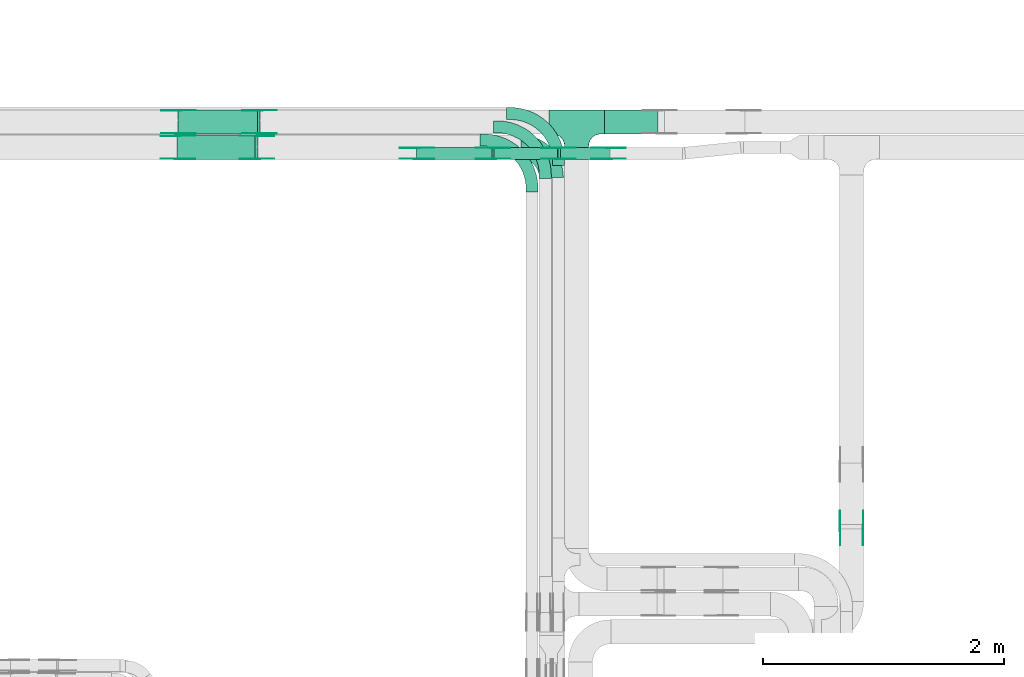
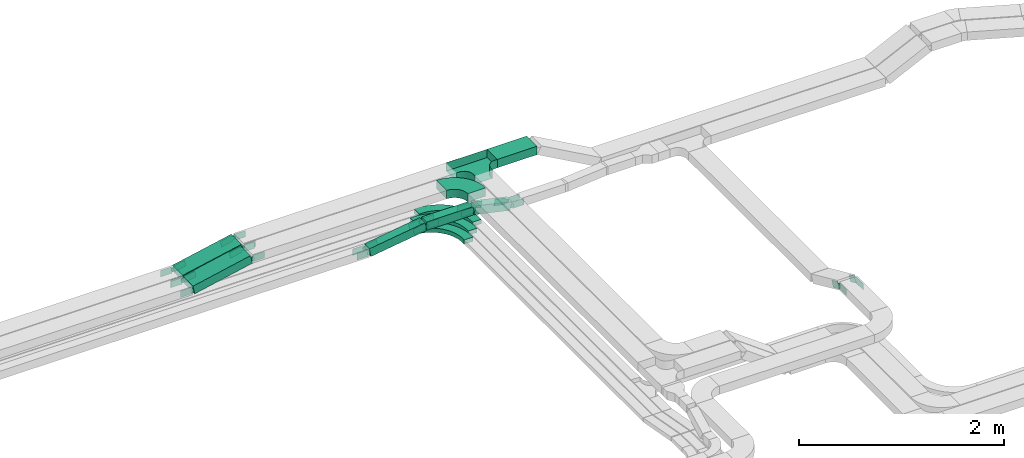
# One storey, part 12 of 23: 41 flow fittings, 6 flow segments.
"""IFC2X3 building model written with IfcOpenShell, lengths in millimetres."""

from ifc_helpers import new_model, entity, si_unit, converted_unit, derived_unit, direction, frame, frame_2d, origin, origin_2d_with_axis, place, context, subcontext, project, spatial, polyline, circle_curve, parameter, trimmed, segment, composite_curve, rectangle, outline, extrude, faceted_brep, source, transform, mapped, material, type_object, type_shapes, element, save


model = new_model("IFC2X3")

# Units and contexts
model_context = context("Model", 3, precision=0.01, world=origin(), true_north=direction((6.12303176911189e-17, 1.0)))
body_context = subcontext(model_context, "Body", "Model", "MODEL_VIEW")
ifc_project = project(units=[si_unit("LENGTHUNIT", "METRE", prefix="MILLI"), si_unit("AREAUNIT", "SQUARE_METRE"), si_unit("VOLUMEUNIT", "CUBIC_METRE"), converted_unit("PLANEANGLEUNIT", "DEGREE", entity("IfcRatioMeasure", 0.0174532925199433), si_unit("PLANEANGLEUNIT", "RADIAN"), dimensions=[0, 0, 0, 0, 0, 0, 0]), si_unit("MASSUNIT", "GRAM", prefix="KILO"), derived_unit("MASSDENSITYUNIT", [(si_unit("MASSUNIT", "GRAM", prefix="KILO"), 1), (si_unit("LENGTHUNIT", "METRE"), -3)]), derived_unit("MOMENTOFINERTIAUNIT", [(si_unit("LENGTHUNIT", "METRE"), 4)]), si_unit("TIMEUNIT", "SECOND"), si_unit("FREQUENCYUNIT", "HERTZ"), si_unit("THERMODYNAMICTEMPERATUREUNIT", "DEGREE_CELSIUS"), derived_unit("THERMALTRANSMITTANCEUNIT", [(si_unit("MASSUNIT", "GRAM", prefix="KILO"), 1), (si_unit("THERMODYNAMICTEMPERATUREUNIT", "KELVIN"), -1), (si_unit("TIMEUNIT", "SECOND"), -3)]), derived_unit("VOLUMETRICFLOWRATEUNIT", [(si_unit("LENGTHUNIT", "METRE"), 3), (si_unit("TIMEUNIT", "SECOND"), -1)]), derived_unit("MASSFLOWRATEUNIT", [(si_unit("MASSUNIT", "GRAM", prefix="KILO"), 1), (si_unit("TIMEUNIT", "SECOND"), -1)]), derived_unit("ROTATIONALFREQUENCYUNIT", [(si_unit("TIMEUNIT", "SECOND"), -1)]), si_unit("ELECTRICCURRENTUNIT", "AMPERE"), si_unit("ELECTRICVOLTAGEUNIT", "VOLT"), si_unit("POWERUNIT", "WATT"), si_unit("FORCEUNIT", "NEWTON", prefix="KILO"), si_unit("ILLUMINANCEUNIT", "LUX"), si_unit("LUMINOUSFLUXUNIT", "LUMEN"), si_unit("LUMINOUSINTENSITYUNIT", "CANDELA"), derived_unit("USERDEFINED", [(si_unit("MASSUNIT", "GRAM", prefix="KILO"), -1), (si_unit("LENGTHUNIT", "METRE"), -2), (si_unit("TIMEUNIT", "SECOND"), 3), (si_unit("LUMINOUSFLUXUNIT", "LUMEN"), 1)]), derived_unit("LINEARVELOCITYUNIT", [(si_unit("LENGTHUNIT", "METRE"), 1), (si_unit("TIMEUNIT", "SECOND"), -1)]), si_unit("PRESSUREUNIT", "PASCAL"), derived_unit("USERDEFINED", [(si_unit("LENGTHUNIT", "METRE"), -2), (si_unit("MASSUNIT", "GRAM", prefix="KILO"), 1), (si_unit("TIMEUNIT", "SECOND"), -2)]), derived_unit("LINEARFORCEUNIT", [(si_unit("MASSUNIT", "GRAM", prefix="KILO"), 1), (si_unit("LENGTHUNIT", "METRE"), 1), (si_unit("TIMEUNIT", "SECOND"), -2), (si_unit("LENGTHUNIT", "METRE"), -1)]), derived_unit("PLANARFORCEUNIT", [(si_unit("MASSUNIT", "GRAM", prefix="KILO"), 1), (si_unit("LENGTHUNIT", "METRE"), 1), (si_unit("TIMEUNIT", "SECOND"), -2), (si_unit("LENGTHUNIT", "METRE"), -2)])], contexts=[model_context])

# Site, building, storey
site_placement = place(None, origin())
site = spatial("IfcSite", under=ifc_project, at=site_placement, CompositionType="ELEMENT")
building_placement = place(site_placement, origin())
building = spatial("IfcBuilding", under=site, at=building_placement, CompositionType="ELEMENT")
storey_placement = place(building_placement, frame((0.0, 0.0, 24000.0)))
storey = spatial("IfcBuildingStorey", under=building, at=storey_placement, CompositionType="ELEMENT", Elevation=24000.0)

# Flow segments
cable_carrier_segment_type = type_object("IfcCableCarrierSegmentType", PredefinedType="CABLETRAYSEGMENT")
flow_segment_1_placement = place(storey_placement, frame((33483.08, 14577.82, 3040.0)))
element("IfcFlowSegment", 1, at=flow_segment_1_placement, inside=storey, type_object=cable_carrier_segment_type, context=body_context, shape_type="SweptSolid", body=[
    extrude(rectangle(XDim=444.928950367665, YDim=200.000000000002, at=origin_2d_with_axis()), frame((222.46, 100.0, 0.0)), (0.0, 0.0, 1.0), 99.9999999999989),
])
flow_segment_2_placement = place(storey_placement, frame((29938.26, 14367.82, 2902.46)))
element("IfcFlowSegment", 2, at=flow_segment_2_placement, inside=storey, type_object=cable_carrier_segment_type, context=body_context, shape_type="SweptSolid", body=[
    extrude(rectangle(XDim=100.000000000002, YDim=199.999999999998, at=frame_2d((0.0, 0.0), x_axis=(0.0, 1.0))), frame((10.36, 100.0, 48.91), z_axis=(0.978296035937588, 0.0, 0.207212128189452), x_axis=(0.0, 1.0, 0.0)), (0.0, 0.0, 1.0), 662.323913296523),
])
flow_segment_3_placement = place(storey_placement, frame((29945.32, 14577.82, 2902.38)))
element("IfcFlowSegment", 3, at=flow_segment_3_placement, inside=storey, type_object=cable_carrier_segment_type, context=body_context, shape_type="SweptSolid", body=[
    extrude(rectangle(XDim=99.9999999999976, YDim=199.999999999998, at=frame_2d((0.0, 0.0), x_axis=(0.0, 1.0))), frame((10.17, 100.0, 48.96), z_axis=(0.979101379108944, 0.0, 0.203372784381206), x_axis=(0.0, 1.0, 0.0)), (0.0, 0.0, 1.0), 675.292929646166),
])
flow_segment_4_placement = place(storey_placement, frame((32566.66, 14367.82, 2743.47)))
element("IfcFlowSegment", 4, at=flow_segment_4_placement, inside=storey, type_object=cable_carrier_segment_type, context=body_context, shape_type="SweptSolid", body=[
    extrude(rectangle(XDim=528.117388360168, YDim=99.9999999999989, at=origin_2d_with_axis()), frame((264.06, 50.0, 0.0)), (0.0, 0.0, 1.0), 100.000000000003),
])
flow_segment_5_placement = place(storey_placement, frame((31923.86, 14367.82, 2651.25)))
element("IfcFlowSegment", 5, at=flow_segment_5_placement, inside=storey, type_object=cable_carrier_segment_type, context=body_context, shape_type="SweptSolid", body=[
    extrude(rectangle(XDim=99.9999999999993, YDim=99.9999999999989, at=origin_2d_with_axis()), frame((7.28, 50.0, 49.47), z_axis=(0.9893540210763, 0.0, 0.145528763411759), x_axis=(-0.145528763411759, 0.0, 0.9893540210763)), (0.0, 0.0, 1.0), 632.403171778338),
])
flow_segment_6_placement = place(storey_placement, frame((33097.62, 14367.82, 2652.7)))
element("IfcFlowSegment", 6, at=flow_segment_6_placement, inside=storey, type_object=cable_carrier_segment_type, context=body_context, shape_type="SweptSolid", body=[
    extrude(rectangle(XDim=99.9999999999984, YDim=99.9999999999989, at=frame_2d((0.0, 0.0), x_axis=(0.0, 1.0))), frame((10.85, 50.0, 139.27), z_axis=(0.976150470581497, 0.0, -0.217095045506624), x_axis=(0.0, 1.0, 0.0)), (0.0, 0.0, 1.0), 416.70105984177),
])

# Flow fittings
ifc_material_1 = material()
cable_carrier_fitting_type_1 = type_object("IfcCableCarrierFittingType", PredefinedType="NOTDEFINED", material=ifc_material_1)
shared_shape_1 = source(origin(), body_context, "Body", "Brep", [
    faceted_brep([(-103.41, -174.12, 50.0), (-100.0, -200.0, 50.0), (-100.0, -230.0, 50.0), (-99.2, -230.0, 50.0), (-99.2, -200.0, 50.0), (-102.63, -173.91, 50.0), (-112.7, -149.6, 50.0), (-128.72, -128.72, 50.0), (-149.6, -112.7, 50.0), (-173.91, -102.63, 50.0), (-200.0, -99.2, 50.0), (-230.0, -99.2, 50.0), (-230.0, -100.0, 50.0), (-200.0, -100.0, 50.0), (-174.12, -103.41, 50.0), (-150.0, -113.4, 50.0), (-129.29, -129.29, 50.0), (-113.4, -150.0, 50.0), (230.0, -100.0, 50.0), (230.0, -99.2, 50.0), (200.0, -99.2, 50.0), (173.91, -102.63, 50.0), (149.6, -112.7, 50.0), (128.72, -128.72, 50.0), (112.7, -149.6, 50.0), (102.63, -173.91, 50.0), (99.2, -200.0, 50.0), (99.2, -230.0, 50.0), (100.0, -230.0, 50.0), (100.0, -200.0, 50.0), (103.41, -174.12, 50.0), (113.4, -150.0, 50.0), (129.29, -129.29, 50.0), (150.0, -113.4, 50.0), (174.12, -103.41, 50.0), (200.0, -100.0, 50.0), (230.0, 99.2, 50.0), (230.0, 100.0, 50.0), (-230.0, 100.0, 50.0), (-230.0, 99.2, 50.0), (-230.0, -100.0, -50.0), (-230.0, 100.0, -50.0), (230.0, 100.0, -50.0), (230.0, -100.0, -50.0), (200.0, -100.0, -50.0), (174.12, -103.41, -50.0), (150.0, -113.4, -50.0), (129.29, -129.29, -50.0), (113.4, -150.0, -50.0), (103.41, -174.12, -50.0), (100.0, -200.0, -50.0), (100.0, -230.0, -50.0), (-100.0, -230.0, -50.0), (-100.0, -200.0, -50.0), (-103.41, -174.12, -50.0), (-113.4, -150.0, -50.0), (-129.29, -129.29, -50.0), (-150.0, -113.4, -50.0), (-174.12, -103.41, -50.0), (-200.0, -100.0, -50.0), (-100.0, -200.0, -49.2), (99.2, -230.0, -49.2), (-99.2, -230.0, -49.2), (-99.2, -200.0, -49.2), (-200.0, -99.2, -49.2), (-230.0, -99.2, -49.2), (230.0, -99.2, -49.2), (200.0, -99.2, -49.2), (-230.0, 99.2, -49.2), (-200.0, -100.0, -49.2), (200.0, -100.0, -49.2), (230.0, 99.2, -49.2), (99.2, -200.0, -49.2), (100.0, -200.0, -49.2), (-173.91, -102.63, -49.2), (-149.6, -112.7, -49.2), (-128.72, -128.72, -49.2), (-112.7, -149.6, -49.2), (-102.63, -173.91, -49.2), (102.63, -173.91, -49.2), (112.7, -149.6, -49.2), (128.72, -128.72, -49.2), (149.6, -112.7, -49.2), (173.91, -102.63, -49.2)], [[[0, 1, 2, 3, 4, 5, 6, 7, 8, 9, 10, 11, 12, 13, 14, 15, 16, 17]], [[18, 19, 20, 21, 22, 23, 24, 25, 26, 27, 28, 29, 30, 31, 32, 33, 34, 35]], [[36, 37, 38, 39]], [[40, 41, 42, 43, 44, 45, 46, 47, 48, 49, 50, 51, 52, 53, 54, 55, 56, 57, 58, 59]], [[2, 1, 60, 53, 52]], [[3, 2, 52, 51, 28, 27, 61, 62]], [[4, 3, 62, 63]], [[11, 10, 64, 65]], [[20, 19, 66, 67]], [[39, 38, 41, 40, 12, 11, 65, 68]], [[13, 12, 40, 59, 69]], [[18, 35, 70, 44, 43]], [[19, 18, 43, 42, 37, 36, 71, 66]], [[27, 26, 72, 61]], [[29, 28, 51, 50, 73]], [[38, 37, 42, 41]], [[36, 39, 68, 71]], [[68, 65, 64, 74, 75, 76, 77, 78, 63, 62, 61, 72, 79, 80, 81, 82, 83, 67, 66, 71]], [[14, 13, 69, 59, 58]], [[15, 14, 58, 57]], [[57, 56, 16, 15]], [[17, 16, 56, 55]], [[0, 17, 55, 54]], [[1, 0, 54, 53, 60]], [[5, 78, 77, 6]], [[6, 77, 76, 7]], [[63, 78, 5, 4]], [[8, 75, 74, 9]], [[9, 74, 64, 10]], [[7, 76, 75, 8]], [[21, 83, 82, 22]], [[22, 82, 81, 23]], [[67, 83, 21, 20]], [[24, 80, 79, 25]], [[25, 79, 72, 26]], [[23, 81, 80, 24]], [[30, 29, 73, 50, 49]], [[31, 30, 49, 48]], [[32, 31, 48, 47]], [[34, 33, 46, 45]], [[34, 45, 44, 70, 35]], [[46, 33, 32, 47]]]),
])
type_shapes(cable_carrier_fitting_type_1, [shared_shape_1])
flow_fitting_1_placement = place(storey_placement, frame((33253.08, 14677.82, 3090.0)))
element("IfcFlowFitting", 7, at=flow_fitting_1_placement, inside=storey, type_object=cable_carrier_fitting_type_1, material=ifc_material_1, Name="470_DKC_S5_T", context=body_context, shape_type="MappedRepresentation", body=[
    mapped(shared_shape_1, transform((0.0, 0.0, 0.0), scale=1.0)),
])
cable_carrier_fitting_type_2 = type_object("IfcCableCarrierFittingType", Name="470_DKC_S5_Variable Angle Elbow 0-45:-", PredefinedType="NOTDEFINED", material=ifc_material_1)
shared_shape_2 = source(origin(), body_context, "Body", "SweptSolid", [
    extrude(outline(composite_curve([segment(polyline([(-125.75, -225.25), (-124.75, -225.25)]), True, "CONTINUOUS"), segment(trimmed(circle_curve(frame_2d((-124.75, 124.75), x_axis=(0.0, -1.0)), 350.0), [parameter(0.0)], [parameter(90.0000000000001)], True, "PARAMETER"), True, "CONTINUOUS"), segment(polyline([(225.25, 124.75), (225.25, 125.75)]), True, "CONTINUOUS"), segment(polyline([(225.25, 125.75), (25.25, 125.75)]), True, "CONTINUOUS"), segment(polyline([(25.25, 125.75), (25.25, 124.75)]), True, "CONTINUOUS"), segment(trimmed(circle_curve(frame_2d((-124.75, 124.75), x_axis=(0.0, -1.0)), 150.0), [parameter(0.0)], [parameter(90.0000000000001)], True, "PARAMETER"), False, "CONTINUOUS"), segment(polyline([(-124.75, -25.25), (-125.75, -25.25)]), True, "CONTINUOUS"), segment(polyline([(-125.75, -25.25), (-125.75, -225.25)]), True, "CONTINUOUS")], self_intersect=False)), frame((-125.25, 125.25, -50.0)), (0.0, 0.0, 1.0), 100.0),
])
type_shapes(cable_carrier_fitting_type_2, [shared_shape_2])
flow_fitting_2_placement = place(storey_placement, frame((33043.08, 14467.82, 3090.0), z_axis=(0.0, 0.0, 1.0), x_axis=(0.0, 1.0, 0.0)))
element("IfcFlowFitting", 8, at=flow_fitting_2_placement, inside=storey, type_object=cable_carrier_fitting_type_2, material=ifc_material_1, Name="470_DKC_S5_Variable Angle Elbow 0-45:-", ObjectType="470_DKC_S5_Variable Angle Elbow 0-45:-", context=body_context, shape_type="MappedRepresentation", body=[
    mapped(shared_shape_2, transform((0.0, 0.0, 0.0), scale=1.0)),
])
ifc_material_2 = material(Name="G")
cable_carrier_fitting_type_3 = type_object("IfcCableCarrierFittingType", PredefinedType="NOTDEFINED", material=ifc_material_2)
shared_shape_3 = source(origin(), body_context, "Body", "SweptSolid", [
    extrude(outline(composite_curve([segment(trimmed(circle_curve(frame_2d((-41.47, 0.0), x_axis=(1.0, 0.0)), 25.0), [parameter(90.0000000000007)], [parameter(270.0)], True, "PARAMETER"), True, "CONTINUOUS"), segment(polyline([(-41.47, -25.0), (-29.97, -25.0)]), True, "CONTINUOUS"), segment(polyline([(-29.97, -25.0), (-28.1, -38.5)]), True, "CONTINUOUS"), segment(polyline([(-28.1, -38.5), (99.53, -38.5)]), True, "CONTINUOUS"), segment(polyline([(99.53, -38.5), (99.53, 38.5)]), True, "CONTINUOUS"), segment(polyline([(99.53, 38.5), (-28.1, 38.5)]), True, "CONTINUOUS"), segment(polyline([(-28.1, 38.5), (-29.97, 25.0)]), True, "CONTINUOUS"), segment(polyline([(-29.97, 25.0), (-41.47, 25.0)]), True, "CONTINUOUS")], self_intersect=False)), frame((41.47, 0.0, 0.0), z_axis=(0.0, 0.0, -1.0), x_axis=(1.0, 0.0, 0.0)), (0.0, 0.0, -1.0), 2.0),
])
type_shapes(cable_carrier_fitting_type_3, [shared_shape_3])
flow_fitting_3_placement = place(storey_placement, frame((29942.11, 14372.36, 2950.0), z_axis=(0.0, -1.0, 0.0), x_axis=(0.978296035937579, 0.0, 0.207212128189496)))
element("IfcFlowFitting", 9, at=flow_fitting_3_placement, inside=storey, type_object=cable_carrier_fitting_type_3, material=ifc_material_2, context=body_context, shape_type="MappedRepresentation", body=[
    mapped(shared_shape_3, transform((0.0, 0.0, 0.0), scale=1.0)),
])
cable_carrier_fitting_type_4 = type_object("IfcCableCarrierFittingType", PredefinedType="NOTDEFINED", material=ifc_material_2)
type_shapes(cable_carrier_fitting_type_4, [shared_shape_3])
flow_fitting_4_placement = place(storey_placement, frame((29942.11, 14561.28, 2950.0), z_axis=(0.0, 1.0, 0.0), x_axis=(-1.0, 0.0, 0.0)))
element("IfcFlowFitting", 10, at=flow_fitting_4_placement, inside=storey, type_object=cable_carrier_fitting_type_4, material=ifc_material_2, context=body_context, shape_type="MappedRepresentation", body=[
    mapped(shared_shape_3, transform((0.0, 0.0, 0.0), scale=1.0)),
])
flow_fitting_5_placement = place(storey_placement, frame((30603.08, 14372.36, 3090.0), z_axis=(0.0, -1.0, 0.0), x_axis=(-0.978296035937579, 0.0, -0.207212128189496)))
element("IfcFlowFitting", 11, at=flow_fitting_5_placement, inside=storey, type_object=cable_carrier_fitting_type_3, material=ifc_material_2, context=body_context, shape_type="MappedRepresentation", body=[
    mapped(shared_shape_3, transform((0.0, 0.0, 0.0), scale=1.0)),
])
flow_fitting_6_placement = place(storey_placement, frame((30603.08, 14561.28, 3090.0), z_axis=(0.0, 1.0, 0.0), x_axis=(1.0, 0.0, 0.0)))
element("IfcFlowFitting", 12, at=flow_fitting_6_placement, inside=storey, type_object=cable_carrier_fitting_type_4, material=ifc_material_2, context=body_context, shape_type="MappedRepresentation", body=[
    mapped(shared_shape_3, transform((0.0, 0.0, 0.0), scale=1.0)),
])
flow_fitting_7_placement = place(storey_placement, frame((29949.08, 14582.36, 2950.0), z_axis=(0.0, -1.0, 0.0), x_axis=(0.979101379108938, 0.0, 0.203372784381233)))
element("IfcFlowFitting", 13, at=flow_fitting_7_placement, inside=storey, type_object=cable_carrier_fitting_type_3, material=ifc_material_2, context=body_context, shape_type="MappedRepresentation", body=[
    mapped(shared_shape_3, transform((0.0, 0.0, 0.0), scale=1.0)),
])
flow_fitting_8_placement = place(storey_placement, frame((29949.08, 14771.28, 2950.0), z_axis=(0.0, 1.0, 0.0), x_axis=(-1.0, 0.0, 0.0)))
element("IfcFlowFitting", 14, at=flow_fitting_8_placement, inside=storey, type_object=cable_carrier_fitting_type_4, material=ifc_material_2, context=body_context, shape_type="MappedRepresentation", body=[
    mapped(shared_shape_3, transform((0.0, 0.0, 0.0), scale=1.0)),
])
flow_fitting_9_placement = place(storey_placement, frame((32561.71, 14372.36, 2793.47), z_axis=(0.0, -1.0, 0.0), x_axis=(-0.989354021076303, 0.0, -0.145528763411741)))
element("IfcFlowFitting", 15, at=flow_fitting_9_placement, inside=storey, type_object=cable_carrier_fitting_type_3, material=ifc_material_2, context=body_context, shape_type="MappedRepresentation", body=[
    mapped(shared_shape_3, transform((0.0, 0.0, 0.0), scale=1.0)),
])
flow_fitting_10_placement = place(storey_placement, frame((32561.71, 14461.28, 2793.47), z_axis=(0.0, 1.0, 0.0), x_axis=(1.0, 0.0, 0.0)))
element("IfcFlowFitting", 16, at=flow_fitting_10_placement, inside=storey, type_object=cable_carrier_fitting_type_4, material=ifc_material_2, context=body_context, shape_type="MappedRepresentation", body=[
    mapped(shared_shape_3, transform((0.0, 0.0, 0.0), scale=1.0)),
])
flow_fitting_11_placement = place(storey_placement, frame((31926.24, 14372.36, 2700.0), z_axis=(0.0, -1.0, 0.0), x_axis=(0.989354021076303, 0.0, 0.145528763411741)))
element("IfcFlowFitting", 17, at=flow_fitting_11_placement, inside=storey, type_object=cable_carrier_fitting_type_3, material=ifc_material_2, context=body_context, shape_type="MappedRepresentation", body=[
    mapped(shared_shape_3, transform((0.0, 0.0, 0.0), scale=1.0)),
])
flow_fitting_12_placement = place(storey_placement, frame((31926.24, 14461.28, 2700.0), z_axis=(0.0, 1.0, 0.0), x_axis=(-1.0, 0.0, 0.0)))
element("IfcFlowFitting", 18, at=flow_fitting_12_placement, inside=storey, type_object=cable_carrier_fitting_type_4, material=ifc_material_2, context=body_context, shape_type="MappedRepresentation", body=[
    mapped(shared_shape_3, transform((0.0, 0.0, 0.0), scale=1.0)),
])
flow_fitting_13_placement = place(storey_placement, frame((33101.71, 14463.28, 2793.47), z_axis=(0.0, 1.0, 0.0), x_axis=(0.976150470581499, 0.0, -0.217095045506614)))
element("IfcFlowFitting", 19, at=flow_fitting_13_placement, inside=storey, type_object=cable_carrier_fitting_type_3, material=ifc_material_2, context=body_context, shape_type="MappedRepresentation", body=[
    mapped(shared_shape_3, transform((0.0, 0.0, 0.0), scale=1.0)),
])
flow_fitting_14_placement = place(storey_placement, frame((33101.71, 14374.36, 2793.47), z_axis=(0.0, -1.0, 0.0), x_axis=(-1.0, 0.0, 0.0)))
element("IfcFlowFitting", 20, at=flow_fitting_14_placement, inside=storey, type_object=cable_carrier_fitting_type_4, material=ifc_material_2, context=body_context, shape_type="MappedRepresentation", body=[
    mapped(shared_shape_3, transform((0.0, 0.0, 0.0), scale=1.0)),
])
flow_fitting_15_placement = place(storey_placement, frame((33522.0, 14463.28, 2700.0), z_axis=(0.0, 1.0, 0.0), x_axis=(-0.976150470581499, 0.0, 0.217095045506614)))
element("IfcFlowFitting", 21, at=flow_fitting_15_placement, inside=storey, type_object=cable_carrier_fitting_type_3, material=ifc_material_2, context=body_context, shape_type="MappedRepresentation", body=[
    mapped(shared_shape_3, transform((0.0, 0.0, 0.0), scale=1.0)),
])
flow_fitting_16_placement = place(storey_placement, frame((33522.0, 14374.36, 2700.0), z_axis=(0.0, -1.0, 0.0), x_axis=(1.0, 0.0, 0.0)))
element("IfcFlowFitting", 22, at=flow_fitting_16_placement, inside=storey, type_object=cable_carrier_fitting_type_4, material=ifc_material_2, context=body_context, shape_type="MappedRepresentation", body=[
    mapped(shared_shape_3, transform((0.0, 0.0, 0.0), scale=1.0)),
])
flow_fitting_17_placement = place(storey_placement, frame((30623.08, 14773.28, 3090.0), z_axis=(0.0, 1.0, 0.0), x_axis=(1.0, 0.0, 0.0)))
element("IfcFlowFitting", 23, at=flow_fitting_17_placement, inside=storey, type_object=cable_carrier_fitting_type_3, material=ifc_material_2, context=body_context, shape_type="MappedRepresentation", body=[
    mapped(shared_shape_3, transform((0.0, 0.0, 0.0), scale=1.0)),
])
flow_fitting_18_placement = place(storey_placement, frame((30623.08, 14584.36, 3090.0), z_axis=(0.0, -1.0, 0.0), x_axis=(-0.979101379108942, 0.0, -0.203372784381214)))
element("IfcFlowFitting", 24, at=flow_fitting_18_placement, inside=storey, type_object=cable_carrier_fitting_type_4, material=ifc_material_2, context=body_context, shape_type="MappedRepresentation", body=[
    mapped(shared_shape_3, transform((0.0, 0.0, 0.0), scale=1.0)),
])
flow_fitting_19_placement = place(storey_placement, frame((35440.16, 11307.82, 2940.0), z_axis=(-1.0, 0.0, 0.0), x_axis=(0.0, 0.910954180221981, -0.412507553307936)))
element("IfcFlowFitting", 25, at=flow_fitting_19_placement, inside=storey, type_object=cable_carrier_fitting_type_3, material=ifc_material_2, context=body_context, shape_type="MappedRepresentation", body=[
    mapped(shared_shape_3, transform((0.0, 0.0, 0.0), scale=1.0)),
])
flow_fitting_20_placement = place(storey_placement, frame((35629.08, 11307.82, 2940.0), z_axis=(1.0, 0.0, 0.0), x_axis=(0.0, -1.0, 0.0)))
element("IfcFlowFitting", 26, at=flow_fitting_20_placement, inside=storey, type_object=cable_carrier_fitting_type_4, material=ifc_material_2, context=body_context, shape_type="MappedRepresentation", body=[
    mapped(shared_shape_3, transform((0.0, 0.0, 0.0), scale=1.0)),
])
cable_carrier_fitting_type_5 = type_object("IfcCableCarrierFittingType", PredefinedType="NOTDEFINED", material=ifc_material_2)
shared_shape_4 = source(origin(), body_context, "Body", "SweptSolid", [
    extrude(outline(composite_curve([segment(trimmed(circle_curve(frame_2d((-41.47, 0.0), x_axis=(1.0, 0.0)), 25.0), [parameter(90.0000000000007)], [parameter(270.0)], True, "PARAMETER"), True, "CONTINUOUS"), segment(polyline([(-41.47, -25.0), (-29.97, -25.0)]), True, "CONTINUOUS"), segment(polyline([(-29.97, -25.0), (-28.1, -38.5)]), True, "CONTINUOUS"), segment(polyline([(-28.1, -38.5), (99.53, -38.5)]), True, "CONTINUOUS"), segment(polyline([(99.53, -38.5), (99.53, 38.5)]), True, "CONTINUOUS"), segment(polyline([(99.53, 38.5), (-28.1, 38.5)]), True, "CONTINUOUS"), segment(polyline([(-28.1, 38.5), (-29.97, 25.0)]), True, "CONTINUOUS"), segment(polyline([(-29.97, 25.0), (-41.47, 25.0)]), True, "CONTINUOUS")], self_intersect=False)), frame((41.47, 0.0, 0.0)), (0.0, 0.0, 1.0), 2.0),
])
type_shapes(cable_carrier_fitting_type_5, [shared_shape_4])
flow_fitting_21_placement = place(storey_placement, frame((29942.11, 14563.28, 2950.0), z_axis=(0.0, 1.0, 0.0), x_axis=(0.978296035937579, 0.0, 0.207212128189496)))
element("IfcFlowFitting", 27, at=flow_fitting_21_placement, inside=storey, type_object=cable_carrier_fitting_type_5, material=ifc_material_2, context=body_context, shape_type="MappedRepresentation", body=[
    mapped(shared_shape_4, transform((0.0, 0.0, 0.0), scale=1.0)),
])
cable_carrier_fitting_type_6 = type_object("IfcCableCarrierFittingType", PredefinedType="NOTDEFINED", material=ifc_material_2)
type_shapes(cable_carrier_fitting_type_6, [shared_shape_4])
flow_fitting_22_placement = place(storey_placement, frame((29942.11, 14374.36, 2950.0), z_axis=(0.0, -1.0, 0.0), x_axis=(-1.0, 0.0, 0.0)))
element("IfcFlowFitting", 28, at=flow_fitting_22_placement, inside=storey, type_object=cable_carrier_fitting_type_6, material=ifc_material_2, context=body_context, shape_type="MappedRepresentation", body=[
    mapped(shared_shape_4, transform((0.0, 0.0, 0.0), scale=1.0)),
])
flow_fitting_23_placement = place(storey_placement, frame((30603.08, 14563.28, 3090.0), z_axis=(0.0, 1.0, 0.0), x_axis=(-0.978296035937579, 0.0, -0.207212128189496)))
element("IfcFlowFitting", 29, at=flow_fitting_23_placement, inside=storey, type_object=cable_carrier_fitting_type_5, material=ifc_material_2, context=body_context, shape_type="MappedRepresentation", body=[
    mapped(shared_shape_4, transform((0.0, 0.0, 0.0), scale=1.0)),
])
flow_fitting_24_placement = place(storey_placement, frame((30603.08, 14374.36, 3090.0), z_axis=(0.0, -1.0, 0.0), x_axis=(1.0, 0.0, 0.0)))
element("IfcFlowFitting", 30, at=flow_fitting_24_placement, inside=storey, type_object=cable_carrier_fitting_type_6, material=ifc_material_2, context=body_context, shape_type="MappedRepresentation", body=[
    mapped(shared_shape_4, transform((0.0, 0.0, 0.0), scale=1.0)),
])
flow_fitting_25_placement = place(storey_placement, frame((29949.08, 14773.28, 2950.0), z_axis=(0.0, 1.0, 0.0), x_axis=(0.979101379108938, 0.0, 0.203372784381233)))
element("IfcFlowFitting", 31, at=flow_fitting_25_placement, inside=storey, type_object=cable_carrier_fitting_type_5, material=ifc_material_2, context=body_context, shape_type="MappedRepresentation", body=[
    mapped(shared_shape_4, transform((0.0, 0.0, 0.0), scale=1.0)),
])
flow_fitting_26_placement = place(storey_placement, frame((29949.08, 14584.36, 2950.0), z_axis=(0.0, -1.0, 0.0), x_axis=(-1.0, 0.0, 0.0)))
element("IfcFlowFitting", 32, at=flow_fitting_26_placement, inside=storey, type_object=cable_carrier_fitting_type_6, material=ifc_material_2, context=body_context, shape_type="MappedRepresentation", body=[
    mapped(shared_shape_4, transform((0.0, 0.0, 0.0), scale=1.0)),
])
flow_fitting_27_placement = place(storey_placement, frame((32561.71, 14463.28, 2793.47), z_axis=(0.0, 1.0, 0.0), x_axis=(-0.989354021076303, 0.0, -0.145528763411741)))
element("IfcFlowFitting", 33, at=flow_fitting_27_placement, inside=storey, type_object=cable_carrier_fitting_type_5, material=ifc_material_2, context=body_context, shape_type="MappedRepresentation", body=[
    mapped(shared_shape_4, transform((0.0, 0.0, 0.0), scale=1.0)),
])
flow_fitting_28_placement = place(storey_placement, frame((32561.71, 14374.36, 2793.47), z_axis=(0.0, -1.0, 0.0), x_axis=(1.0, 0.0, 0.0)))
element("IfcFlowFitting", 34, at=flow_fitting_28_placement, inside=storey, type_object=cable_carrier_fitting_type_6, material=ifc_material_2, context=body_context, shape_type="MappedRepresentation", body=[
    mapped(shared_shape_4, transform((0.0, 0.0, 0.0), scale=1.0)),
])
flow_fitting_29_placement = place(storey_placement, frame((31926.24, 14463.28, 2700.0), z_axis=(0.0, 1.0, 0.0), x_axis=(0.989354021076303, 0.0, 0.145528763411741)))
element("IfcFlowFitting", 35, at=flow_fitting_29_placement, inside=storey, type_object=cable_carrier_fitting_type_5, material=ifc_material_2, context=body_context, shape_type="MappedRepresentation", body=[
    mapped(shared_shape_4, transform((0.0, 0.0, 0.0), scale=1.0)),
])
flow_fitting_30_placement = place(storey_placement, frame((31926.24, 14374.36, 2700.0), z_axis=(0.0, -1.0, 0.0), x_axis=(-1.0, 0.0, 0.0)))
element("IfcFlowFitting", 36, at=flow_fitting_30_placement, inside=storey, type_object=cable_carrier_fitting_type_6, material=ifc_material_2, context=body_context, shape_type="MappedRepresentation", body=[
    mapped(shared_shape_4, transform((0.0, 0.0, 0.0), scale=1.0)),
])
flow_fitting_31_placement = place(storey_placement, frame((33101.71, 14372.36, 2793.47), z_axis=(0.0, -1.0, 0.0), x_axis=(0.976150470581499, 0.0, -0.217095045506614)))
element("IfcFlowFitting", 37, at=flow_fitting_31_placement, inside=storey, type_object=cable_carrier_fitting_type_5, material=ifc_material_2, context=body_context, shape_type="MappedRepresentation", body=[
    mapped(shared_shape_4, transform((0.0, 0.0, 0.0), scale=1.0)),
])
flow_fitting_32_placement = place(storey_placement, frame((33101.71, 14461.28, 2793.47), z_axis=(0.0, 1.0, 0.0), x_axis=(-1.0, 0.0, 0.0)))
element("IfcFlowFitting", 38, at=flow_fitting_32_placement, inside=storey, type_object=cable_carrier_fitting_type_6, material=ifc_material_2, context=body_context, shape_type="MappedRepresentation", body=[
    mapped(shared_shape_4, transform((0.0, 0.0, 0.0), scale=1.0)),
])
flow_fitting_33_placement = place(storey_placement, frame((33522.0, 14372.36, 2700.0), z_axis=(0.0, -1.0, 0.0), x_axis=(-0.976150470581499, 0.0, 0.217095045506614)))
element("IfcFlowFitting", 39, at=flow_fitting_33_placement, inside=storey, type_object=cable_carrier_fitting_type_5, material=ifc_material_2, context=body_context, shape_type="MappedRepresentation", body=[
    mapped(shared_shape_4, transform((0.0, 0.0, 0.0), scale=1.0)),
])
flow_fitting_34_placement = place(storey_placement, frame((33522.0, 14461.28, 2700.0), z_axis=(0.0, 1.0, 0.0), x_axis=(1.0, 0.0, 0.0)))
element("IfcFlowFitting", 40, at=flow_fitting_34_placement, inside=storey, type_object=cable_carrier_fitting_type_6, material=ifc_material_2, context=body_context, shape_type="MappedRepresentation", body=[
    mapped(shared_shape_4, transform((0.0, 0.0, 0.0), scale=1.0)),
])
flow_fitting_35_placement = place(storey_placement, frame((30623.08, 14582.36, 3090.0), z_axis=(0.0, -1.0, 0.0), x_axis=(1.0, 0.0, 0.0)))
element("IfcFlowFitting", 41, at=flow_fitting_35_placement, inside=storey, type_object=cable_carrier_fitting_type_5, material=ifc_material_2, context=body_context, shape_type="MappedRepresentation", body=[
    mapped(shared_shape_4, transform((0.0, 0.0, 0.0), scale=1.0)),
])
flow_fitting_36_placement = place(storey_placement, frame((30623.08, 14771.28, 3090.0), z_axis=(0.0, 1.0, 0.0), x_axis=(-0.979101379108942, 0.0, -0.203372784381214)))
element("IfcFlowFitting", 42, at=flow_fitting_36_placement, inside=storey, type_object=cable_carrier_fitting_type_6, material=ifc_material_2, context=body_context, shape_type="MappedRepresentation", body=[
    mapped(shared_shape_4, transform((0.0, 0.0, 0.0), scale=1.0)),
])
flow_fitting_37_placement = place(storey_placement, frame((35631.08, 11307.82, 2940.0), z_axis=(1.0, 0.0, 0.0), x_axis=(0.0, 0.910954180221981, -0.412507553307936)))
element("IfcFlowFitting", 43, at=flow_fitting_37_placement, inside=storey, type_object=cable_carrier_fitting_type_5, material=ifc_material_2, context=body_context, shape_type="MappedRepresentation", body=[
    mapped(shared_shape_4, transform((0.0, 0.0, 0.0), scale=1.0)),
])
flow_fitting_38_placement = place(storey_placement, frame((35442.16, 11307.82, 2940.0), z_axis=(-1.0, 0.0, 0.0), x_axis=(0.0, -1.0, 0.0)))
element("IfcFlowFitting", 44, at=flow_fitting_38_placement, inside=storey, type_object=cable_carrier_fitting_type_6, material=ifc_material_2, context=body_context, shape_type="MappedRepresentation", body=[
    mapped(shared_shape_4, transform((0.0, 0.0, 0.0), scale=1.0)),
])
cable_carrier_fitting_type_7 = type_object("IfcCableCarrierFittingType", Name="470_DKC_S5_CPO 45 horizontal angle:-", PredefinedType="NOTDEFINED", material=ifc_material_1)
shared_shape_5 = source(origin(), body_context, "Body", "SweptSolid", [
    extrude(outline(composite_curve([segment(polyline([(-222.5, -257.5), (-192.5, -257.5)]), True, "CONTINUOUS"), segment(trimmed(circle_curve(frame_2d((-192.5, 192.5), x_axis=(0.0, -1.0)), 450.0), [parameter(0.0)], [parameter(90.0)], True, "PARAMETER"), True, "CONTINUOUS"), segment(polyline([(257.5, 192.5), (257.5, 222.5)]), True, "CONTINUOUS"), segment(polyline([(257.5, 222.5), (157.5, 222.5)]), True, "CONTINUOUS"), segment(polyline([(157.5, 222.5), (157.5, 192.5)]), True, "CONTINUOUS"), segment(trimmed(circle_curve(frame_2d((-192.5, 192.5), x_axis=(0.0, -1.0)), 350.0), [parameter(0.0)], [parameter(90.0)], True, "PARAMETER"), False, "CONTINUOUS"), segment(polyline([(-192.5, -157.5), (-222.5, -157.5)]), True, "CONTINUOUS"), segment(polyline([(-222.5, -157.5), (-222.5, -257.5)]), True, "CONTINUOUS")], self_intersect=False)), frame((-207.5, 207.5, -25.0)), (0.0, 0.0, 1.0), 50.0000000000002),
])
type_shapes(cable_carrier_fitting_type_7, [shared_shape_5])
for number, where, z_axis, x_axis, name in (
    (45, (32883.08, 14527.82, 2675.0), (0.0, 0.0, 1.0), (0.0, 1.0, 0.0), "470_DKC_S5_45 horizontal angle"),
    (46, (32993.08, 14637.82, 2675.0), (0.0, 0.0, 1.0), (0.0, 1.0, 0.0), "470_DKC_S5_45 horizontal angle"),
    (47, (33103.08, 14747.82, 2675.0), (0.0, 0.0, 1.0), (0.0, 1.0, 0.0), "470_DKC_S5_45 horizontal angle"),
):
    element("IfcFlowFitting", number, at=place(storey_placement, frame(where, z_axis=z_axis, x_axis=x_axis)), inside=storey, type_object=cable_carrier_fitting_type_7, material=ifc_material_1, Name=name, ObjectType="470_DKC_S5_CPO 45 horizontal angle:-", context=body_context, shape_type="MappedRepresentation", body=[
        mapped(shared_shape_5, transform((0.0, 0.0, 0.0), scale=1.0)),
    ])

save(model, "model.ifc")
